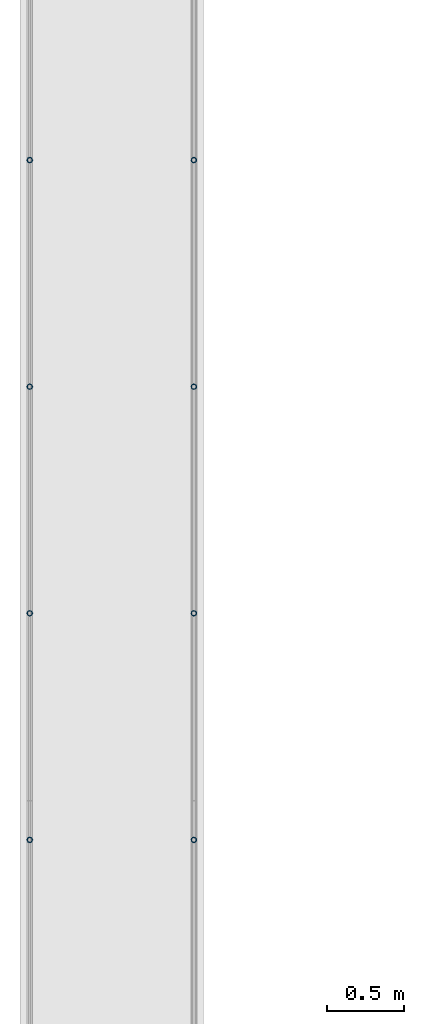
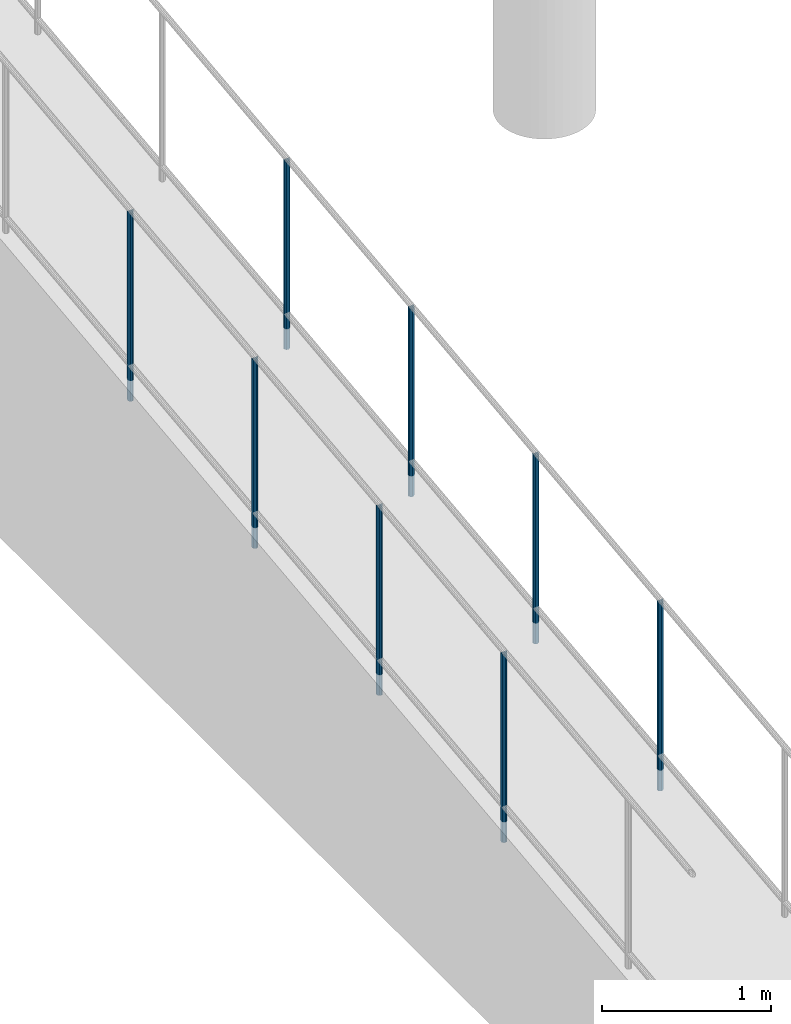
# One storey, part 881 of 1763: 8 columns, 4 elements without a shape of their own.
"""IFC2X3 building model written with IfcOpenShell, lengths in millimetres."""

import ifcopenshell
import ifcopenshell.guid

model = None  # the IFC model being written
_history = None  # IfcOwnerHistory: only IFC2X3 demands one
_inside = {}  # id of a spatial element -> (the spatial element, [elements in it])
_under = {}  # id of a project, library or spatial element -> (it, [spatial elements below it])
_declared = {}  # id of a project -> (the project, [libraries it declares])
_typed = {}  # id of a type object -> (the type object, [elements of that type])
_made_of = {}  # id of a material, layer set ... -> (it, [elements and type objects made of it])


def new_model(schema):
    """Start an empty IFC model of exactly this schema.

    Asked for "IFC4X3", IfcOpenShell would pick the latest addendum, in which some entities
    have other attributes; the version numbers below select the first issue.
    IFC2X3 requires an IfcOwnerHistory on every rooted entity: one is made here for all.
    """
    global model, _history
    if schema == "IFC4X3":
        model = ifcopenshell.file(schema_version=(4, 3, 0, 0))
    else:
        model = ifcopenshell.file(schema=schema)
    _inside.clear()
    _under.clear()
    _declared.clear()
    _typed.clear()
    _made_of.clear()
    _history = None
    if model.schema == "IFC2X3":
        org = make("IfcOrganization", Name="unknown")
        user = make(
            "IfcPersonAndOrganization",
            ThePerson=make("IfcPerson", FamilyName="unknown"),
            TheOrganization=org,
        )
        app = make(
            "IfcApplication",
            ApplicationDeveloper=org,
            Version="unknown",
            ApplicationFullName="unknown",
            ApplicationIdentifier="unknown",
        )
        _history = make(
            "IfcOwnerHistory",
            OwningUser=user,
            OwningApplication=app,
            ChangeAction="ADDED",
            CreationDate=0,
        )
    return model


def make(cls, **values):
    """One entity of the class cls with the attributes given. An attribute that is None is left unset."""
    return model.create_entity(
        cls, **{name: value for name, value in values.items() if value is not None}
    )


def rooted(cls, **values):
    """An entity with a GlobalId (a new one), such as an element, a storey or a relation."""
    return make(cls, GlobalId=ifcopenshell.guid.new(), OwnerHistory=_history, **values)


def si_unit(unit_type, name, prefix=None):
    """IfcSIUnit, for example si_unit("LENGTHUNIT", "METRE", prefix="MILLI")."""
    return make("IfcSIUnit", UnitType=unit_type, Prefix=prefix, Name=name)


def assignment(units):
    """IfcUnitAssignment: the units of a project."""
    return None if units is None else make("IfcUnitAssignment", Units=units)


def point(xyz):
    """IfcCartesianPoint."""
    return None if xyz is None else make("IfcCartesianPoint", Coordinates=xyz)


def direction(xyz):
    """IfcDirection."""
    return None if xyz is None else make("IfcDirection", DirectionRatios=xyz)


def frame(location, z_axis=None, x_axis=None):
    """IfcAxis2Placement3D, a coordinate frame: its origin and axes. An axis left out is left unset."""
    return make(
        "IfcAxis2Placement3D",
        Location=point(location),
        Axis=direction(z_axis),
        RefDirection=direction(x_axis),
    )


def origin_with_axes():
    """The frame at (0, 0, 0) with the z axis (0, 0, 1) and the x axis (1, 0, 0) written out."""
    return frame((0.0, 0.0, 0.0), z_axis=(0.0, 0.0, 1.0), x_axis=(1.0, 0.0, 0.0))


def place(relative_to, where):
    """IfcLocalPlacement: puts the frame where relative to a parent placement (None: the world)."""
    return make(
        "IfcLocalPlacement", PlacementRelTo=relative_to, RelativePlacement=where
    )


def context(
    kind, dimensions, precision=None, world=None, true_north=None, identifier=None
):
    """IfcGeometricRepresentationContext, for example the 3D "Model" context."""
    return make(
        "IfcGeometricRepresentationContext",
        ContextIdentifier=identifier,
        ContextType=kind,
        CoordinateSpaceDimension=dimensions,
        Precision=precision,
        WorldCoordinateSystem=world,
        TrueNorth=true_north,
    )


def subcontext(parent, identifier, kind, view, scale=None):
    """IfcGeometricRepresentationSubContext, for example "Body" below "Model"."""
    return make(
        "IfcGeometricRepresentationSubContext",
        ContextIdentifier=identifier,
        ContextType=kind,
        ParentContext=parent,
        TargetScale=scale,
        TargetView=view,
    )


def project(units=None, contexts=None):
    """IfcProject with its units and contexts."""
    return rooted(
        "IfcProject",
        Name="project",
        RepresentationContexts=contexts,
        UnitsInContext=assignment(units),
    )


def spatial(cls, under=None, at=None, **own):
    """A site, building, storey or space (cls), placed at a placement, below another one or the project."""
    s = rooted(cls, ObjectPlacement=at, **own)
    if under is not None:
        _under.setdefault(under.id(), (under, []))[1].append(s)
    return s


def faces_of(points, faces, orient=None, outer=None):
    """IfcFace entities. A face is a list of loops; a loop is a list of indices into points, from 0.

    orient and outer hold one flag for each loop. By default every Orientation is true, the
    first loop of a face is its IfcFaceOuterBound and the others are IfcFaceBound.
    """
    made = []
    for i, loops in enumerate(faces):
        bounds = []
        for j, loop in enumerate(loops):
            is_outer = j == 0 if outer is None else outer[i][j]
            bounds.append(
                make(
                    "IfcFaceOuterBound" if is_outer else "IfcFaceBound",
                    Bound=make("IfcPolyLoop", Polygon=[points[k] for k in loop]),
                    Orientation=True if orient is None else orient[i][j],
                )
            )
        made.append(make("IfcFace", Bounds=bounds))
    return made


def faceted_brep(points, faces, orient=None, outer=None, voids=None):
    """IfcFacetedBrep: a solid bounded by flat faces; with voids (closed shells), ...WithVoids."""
    shared = [point(p) for p in points]
    hull = make("IfcClosedShell", CfsFaces=faces_of(shared, faces, orient, outer))
    if voids is None:
        return make("IfcFacetedBrep", Outer=hull)
    return make(
        "IfcFacetedBrepWithVoids",
        Outer=hull,
        Voids=[
            make(cls, CfsFaces=faces_of(shared, fs, o, b)) for cls, fs, o, b in voids
        ],
    )


def shape(context_of_items, identifier, shape_type, items):
    """IfcShapeRepresentation: the items that make up one representation, for example the "Body"."""
    return make(
        "IfcShapeRepresentation",
        ContextOfItems=context_of_items,
        RepresentationIdentifier=identifier,
        RepresentationType=shape_type,
        Items=items,
    )


def material(Name=None, Category=None):
    """IfcMaterial."""
    return make("IfcMaterial", Name=Name, Category=Category)


def made_of(thing, what):
    """Note that an element or type object is made of a material, layer set ...; save() writes the relation."""
    if what is not None:
        _made_of.setdefault(what.id(), (what, []))[1].append(thing)
    return thing


def type_object(cls, material=None, **own):
    """A type object (cls), such as IfcWallType, which elements share."""
    return made_of(rooted(cls, **own), material)


def element(
    cls,
    number,
    at=None,
    inside=None,
    cuts=None,
    type_object=None,
    material=None,
    context=None,
    identifier="Body",
    shape_type=None,
    held_by="IfcProductDefinitionShape",
    body=None,
    shapes=None,
    **own,
):
    """One element of the class cls, such as IfcWall. Its Tag is "e" and its number.

    at: its placement. inside: the storey or other place that contains it. cuts: it is an
    opening in that element (IfcRelVoidsElement). A single representation is given by context,
    identifier, shape_type and body (its items); several are given by shapes. held_by: the class
    of the entity that holds the representations. save() writes the other relations.
    """
    e = rooted(cls, Tag="e%d" % number, ObjectPlacement=at, **own)
    if body is not None:
        shapes = [shape(context, identifier, shape_type, body)]
    if shapes is not None:
        e.Representation = make(held_by, Representations=shapes)
    if inside is not None:
        _inside.setdefault(inside.id(), (inside, []))[1].append(e)
    if cuts is not None:
        rooted(
            "IfcRelVoidsElement", RelatingBuildingElement=cuts, RelatedOpeningElement=e
        )
    if type_object is not None:
        _typed.setdefault(type_object.id(), (type_object, []))[1].append(e)
    return made_of(e, material)


def aggregate(whole, parts):
    """IfcRelAggregates: a whole, such as a stair, and the parts it consists of."""
    return rooted("IfcRelAggregates", RelatingObject=whole, RelatedObjects=parts)


def save(model, path):
    """Write the relations noted so far, then the file.

    IfcRelAggregates (storeys below a building ...), IfcRelContainedInSpatialStructure (elements
    in a storey), IfcRelDefinesByType, IfcRelAssociatesMaterial and IfcRelDeclares: one each for
    every whole, place, type object, material and project.
    """
    for whole, parts in _under.values():
        aggregate(whole, parts)
    for where, things in _inside.values():
        rooted(
            "IfcRelContainedInSpatialStructure",
            RelatedElements=things,
            RelatingStructure=where,
        )
    for kind, things in _typed.values():
        rooted("IfcRelDefinesByType", RelatedObjects=things, RelatingType=kind)
    for what, things in _made_of.values():
        rooted("IfcRelAssociatesMaterial", RelatedObjects=things, RelatingMaterial=what)
    for by, libraries in _declared.values():
        rooted("IfcRelDeclares", RelatingContext=by, RelatedDefinitions=libraries)
    model.write(path)


model = new_model("IFC2X3")

# Units and contexts
model_context = context("Model", 3, precision=1e-05, world=origin_with_axes())
body_context = subcontext(model_context, "Body", "Model", "MODEL_VIEW")
ifc_project = project(units=[si_unit("LENGTHUNIT", "METRE", prefix="MILLI"), si_unit("AREAUNIT", "SQUARE_METRE"), si_unit("VOLUMEUNIT", "CUBIC_METRE"), si_unit("MASSUNIT", "GRAM", prefix="KILO"), si_unit("TIMEUNIT", "SECOND"), si_unit("PLANEANGLEUNIT", "RADIAN"), si_unit("SOLIDANGLEUNIT", "STERADIAN"), si_unit("THERMODYNAMICTEMPERATUREUNIT", "DEGREE_CELSIUS"), si_unit("LUMINOUSINTENSITYUNIT", "LUMEN")], contexts=[model_context])

# Site, building, storey
site_placement = place(None, origin_with_axes())
site = spatial("IfcSite", under=ifc_project, at=site_placement, CompositionType="ELEMENT")
building_placement = place(site_placement, origin_with_axes())
building = spatial("IfcBuilding", under=site, at=building_placement, Name="Undefined", CompositionType="ELEMENT")
storey_placement = place(building_placement, origin_with_axes())
storey = spatial("IfcBuildingStorey", under=building, at=storey_placement, Name="Undefined", CompositionType="ELEMENT", Elevation=0.0)

# Assembly, columns
assembly_1_placement = place(storey_placement, origin_with_axes())
assembly_1 = element("IfcElementAssembly", 1, at=assembly_1_placement, inside=storey, Name="GUARDRAIL", AssemblyPlace="NOTDEFINED", PredefinedType="RIGID_FRAME")
ifc_material = material(Name="STEEL/A513")
column_type = type_object("IfcColumnType", PredefinedType="NOTDEFINED")
column_1_placement = place(assembly_1_placement, frame((-97200.6527017878, 1949.23806233376, 5252.99412823663), z_axis=(0.0, -0.999999999989044, 4.68099999989136e-06), x_axis=(0.0, 4.68100000009712e-06, 0.999999999989044)))
column_1 = element("IfcColumn", 2, at=column_1_placement, type_object=column_type, material=ifc_material, Name="POST TUBE", context=body_context, shape_type="Brep", body=[
    faceted_brep([(1371.60068125507, 19.0500000000029, 6.43467501504347e-11), (1360.91947867937, 16.4977839420899, 9.52500000006421), (1363.10672897463, 16.4977839420899, -9.52499999993643), (1352.9316033798, -7.14375000000291, 12.373337956634), (1350.78508867621, 0.0, 14.287500000064), (1350.23827610239, 0.0, 19.0500000000638), (1353.10029570709, -9.52499999999418, 16.4977839421576), (1353.84725557403, -9.52499999997963, 9.99208795664867), (1353.84725557403, 9.52500000000873, 9.99208795661957), (1353.10029570709, 9.52499999999418, 16.4977839421576), (1352.93160337979, 7.14375000000291, 12.373337956634), (1357.04134215904, 12.3733379565674, 7.14375000006385), (1359.78829874193, 14.2875000000058, 6.3664629124105e-11), (1358.68177988048, 12.3733379565674, -7.14374999993652), (1356.14176448041, 9.52500000000873, -9.99208795649247), (1356.88872434735, 9.52499999999418, -16.4977839420305), (1355.77292485998, 7.14375000000291, -12.3733379565072), (1354.0659641191, 0.0, -14.2874999999372), (1354.61277669292, 0.0, -19.049999999937), (1355.77292485999, -7.14375000000291, -12.3733379565072), (1356.14176448041, -9.52499999997963, -9.99208795652157), (1356.88872434735, -9.52499999999418, -16.4977839420305), (1371.60068125632, -19.0499999999884, 2.08501660381444e-10), (1363.10672897463, -16.4977839420899, -9.52499999993643), (1360.91947867937, -16.4977839420899, 9.52500000006421), (1358.68177988052, -12.3733379565674, -7.14374999993652), (1359.78829874197, -14.2875000000058, 6.3664629124105e-11), (1357.04134215908, -12.3733379565674, 7.14375000006407), (0.0, -16.4977839420899, -9.52500000000146), (0.0, -9.52499999999418, -16.4977839420935), (1.45519152283669e-11, 1.81898940354586e-12, -19.0499999999993), (0.0, 9.52499999999418, -16.4977839420935), (0.0, 16.4977839420899, -9.52500000000146), (0.0, 19.0500000000029, 0.0), (0.0, 16.4977839420899, 9.52500000000146), (0.0, 9.52499999999418, 16.4977839420935), (1.45519152283669e-11, 1.81898940354586e-12, 19.0499999999993), (0.0, -9.52499999999418, 16.4977839420935), (0.0, -16.4977839420899, 9.52500000000146), (0.0, -19.0500000000029, 0.0), (0.0, -12.3733379565674, -7.14374999999927), (0.0, -7.14375000000291, -12.373337956571), (0.0, 0.0, -14.2874999999985), (0.0, 7.14375000000291, -12.373337956571), (0.0, 12.3733379565674, -7.14374999999927), (0.0, 14.2875000000058, 0.0), (0.0, 12.3733379565674, 7.14374999999927), (0.0, 7.14375000000291, 12.373337956571), (0.0, 0.0, 14.2874999999985), (0.0, -7.14375000000291, 12.373337956571), (0.0, -12.3733379565674, 7.14374999999927), (0.0, -14.2875000000058, 0.0)], [[[0, 1, 2]], [[3, 4, 5, 6, 7]], [[8, 9, 5, 4, 10]], [[2, 1, 9, 8, 11, 12, 13, 14, 15]], [[15, 14, 16, 17, 18]], [[18, 17, 19, 20, 21]], [[22, 23, 24]], [[21, 20, 25, 26, 27, 7, 6, 24, 23]], [[28, 29, 21, 23]], [[29, 30, 18, 21]], [[30, 31, 15, 18]], [[31, 32, 2, 15]], [[32, 33, 0, 2]], [[33, 34, 1, 0]], [[34, 35, 9, 1]], [[35, 36, 5, 9]], [[36, 37, 6, 5]], [[37, 38, 24, 6]], [[38, 39, 22, 24]], [[39, 28, 23, 22]], [[38, 37, 36, 35, 34, 33, 32, 31, 30, 29, 28, 39], [40, 41, 42, 43, 44, 45, 46, 47, 48, 49, 50, 51]], [[40, 51, 26, 25]], [[19, 41, 40, 25, 20]], [[42, 41, 19, 17]], [[43, 42, 17, 16]], [[44, 43, 16, 14, 13]], [[45, 44, 13, 12]], [[46, 45, 12, 11]], [[10, 47, 46, 11, 8]], [[48, 47, 10, 4]], [[49, 48, 4, 3]], [[50, 49, 3, 7, 27]], [[51, 50, 27, 26]]]),
])
column_2_placement = place(assembly_1_placement, frame((-97200.6527017878, 476.037327690622, 5083.85314479949), z_axis=(0.0, -0.999999999989044, 4.68099999989136e-06), x_axis=(0.0, 4.68100000009712e-06, 0.999999999989044)))
column_2 = element("IfcColumn", 3, at=column_2_placement, type_object=column_type, material=ifc_material, Name="POST TUBE", context=body_context, shape_type="Brep", body=[
    faceted_brep([(1371.60074802696, 19.0500000000029, -4.95674612466246e-10), (1360.91954353543, 16.4977839420899, 9.52499999992688), (1363.1068023618, 16.4977839420899, -9.52500000007285), (1352.93166657158, -7.14375000000291, 12.3733379564974), (1350.78515091293, 0.0, 14.2874999999276), (1350.23833620634, 0.0, 19.0499999999279), (1353.10035708436, -9.52499999999418, 16.4977839420208), (1353.84731986472, -9.52499999997963, 9.99208795651202), (1353.84731986473, 9.52500000000873, 9.99208795648292), (1353.10035708436, 9.52499999999418, 16.4977839420208), (1352.93166657157, 7.14375000000291, 12.3733379564974), (1357.04140787087, 12.3733379565674, 7.14374999992697), (1359.7883677507, 14.2875000000058, -7.27595761418343e-11), (1358.68185199063, 12.3733379565674, -7.14375000007294), (1356.14183772056, 9.52500000000873, -9.99208795662844), (1356.88880050093, 9.52499999999418, -16.4977839421663), (1355.77299913398, 7.14375000000291, -12.3733379566434), (1354.06603915248, 0.0, -14.2875000000727), (1354.61285385908, 0.0, -19.0500000000725), (1355.77299913399, -7.14375000000291, -12.3733379566434), (1356.14183772056, -9.52499999997963, -9.992087956658), (1356.88880050093, -9.52499999999418, -16.4977839421663), (1371.60075086449, -19.0499999999884, 1.21417542686686e-10), (1363.1068023618, -16.4977839420899, -9.52500000007285), (1360.91954353543, -16.4977839420899, 9.52499999992688), (1358.68185199066, -12.3733379565674, -7.14375000007294), (1359.78836775073, -14.2875000000058, -7.27595761418343e-11), (1357.0414078709, -12.3733379565674, 7.14374999992697), (0.0, -16.4977839420899, -9.52500000000146), (0.0, -9.52499999999418, -16.4977839420935), (1.45519152283669e-11, 1.81898940354586e-12, -19.0499999999993), (0.0, 9.52499999999418, -16.4977839420935), (0.0, 16.4977839420899, -9.52500000000146), (0.0, 19.0500000000029, 0.0), (0.0, 16.4977839420899, 9.52500000000146), (0.0, 9.52499999999418, 16.4977839420935), (1.45519152283669e-11, 1.81898940354586e-12, 19.0499999999993), (0.0, -9.52499999999418, 16.4977839420935), (0.0, -16.4977839420899, 9.52500000000146), (0.0, -19.0500000000029, 0.0), (0.0, -12.3733379565674, -7.14374999999927), (0.0, -7.14375000000291, -12.373337956571), (0.0, 0.0, -14.2874999999985), (0.0, 7.14375000000291, -12.373337956571), (0.0, 12.3733379565674, -7.14374999999927), (0.0, 14.2875000000058, 0.0), (0.0, 12.3733379565674, 7.14374999999927), (0.0, 7.14375000000291, 12.373337956571), (0.0, 0.0, 14.2874999999985), (0.0, -7.14375000000291, 12.373337956571), (0.0, -12.3733379565674, 7.14374999999927), (0.0, -14.2875000000058, 0.0)], [[[0, 1, 2]], [[3, 4, 5, 6, 7]], [[8, 9, 5, 4, 10]], [[2, 1, 9, 8, 11, 12, 13, 14, 15]], [[15, 14, 16, 17, 18]], [[18, 17, 19, 20, 21]], [[22, 23, 24]], [[21, 20, 25, 26, 27, 7, 6, 24, 23]], [[28, 29, 21, 23]], [[29, 30, 18, 21]], [[30, 31, 15, 18]], [[31, 32, 2, 15]], [[32, 33, 0, 2]], [[33, 34, 1, 0]], [[34, 35, 9, 1]], [[35, 36, 5, 9]], [[36, 37, 6, 5]], [[37, 38, 24, 6]], [[38, 39, 22, 24]], [[39, 28, 23, 22]], [[38, 37, 36, 35, 34, 33, 32, 31, 30, 29, 28, 39], [40, 41, 42, 43, 44, 45, 46, 47, 48, 49, 50, 51]], [[40, 51, 26, 25]], [[19, 41, 40, 25, 20]], [[42, 41, 19, 17]], [[43, 42, 17, 16]], [[44, 43, 16, 14, 13]], [[45, 44, 13, 12]], [[46, 45, 12, 11]], [[10, 47, 46, 11, 8]], [[48, 47, 10, 4]], [[49, 48, 4, 3]], [[50, 49, 3, 7, 27]], [[51, 50, 27, 26]]]),
])
column_3_placement = place(assembly_1_placement, frame((-97200.6527017878, -997.16267378922, 4914.71224553822), z_axis=(0.0, -0.999999999989044, 4.68099999989136e-06), x_axis=(0.0, 4.68100000009712e-06, 0.999999999989044)))
column_3 = element("IfcColumn", 4, at=column_3_placement, type_object=column_type, material=ifc_material, Name="POST TUBE", context=body_context, shape_type="Brep", body=[
    faceted_brep([(1371.60074802696, 19.0500000000029, -4.95674612466246e-10), (1360.88226427304, 16.4977839420899, 9.52500000002783), (1363.06893704611, 16.4977839420899, -9.5249999999719), (1352.89450163934, -7.14375000000291, 12.3733379565979), (1350.74805158422, 0.0, 14.2875000000276), (1350.20138339095, 0.0, 19.0500000000276), (1353.06331679776, -9.52499999999418, 16.4977839421211), (1353.8100794372, -9.52499999997963, 9.99208795661241), (1353.8100794372, 9.52500000000873, 9.9920879565833), (1353.06331679776, 9.52499999999418, 16.4977839421211), (1352.89450163932, 7.14375000000291, 12.3733379565979), (1357.00406982313, 12.3733379565674, 7.14375000002781), (1359.75080321677, 14.2875000000058, 2.79669620795175e-11), (1358.64407440294, 12.3733379565674, -7.1437499999721), (1356.1039825008, 9.52500000000873, -9.99208795652771), (1356.85074514025, 9.52499999999418, -16.4977839420656), (1355.7350728962, 7.14375000000291, -12.3733379565422), (1354.02806074383, 0.0, -14.2874999999721), (1354.5747289371, 0.0, -19.049999999972), (1355.73507289621, -7.14375000000291, -12.3733379565422), (1356.10398250081, -9.52499999997963, -9.99208795655682), (1356.85074514025, -9.52499999999418, -16.4977839420656), (1371.56363438805, -19.0499999999884, -0.00426213161995292), (1363.06893704611, -16.4977839420899, -9.5249999999719), (1360.88226427304, -16.4977839420899, 9.52500000002783), (1358.64407440297, -12.3733379565674, -7.1437499999721), (1359.7508032168, -14.2875000000058, 2.79669620795175e-11), (1357.00406982317, -12.3733379565674, 7.14375000002781), (0.0, -16.4977839420899, -9.52500000000146), (0.0, -9.52499999999418, -16.4977839420935), (1.45519152283669e-11, 1.81898940354586e-12, -19.0499999999993), (0.0, 9.52499999999418, -16.4977839420935), (0.0, 16.4977839420899, -9.52500000000146), (0.0, 19.0500000000029, 0.0), (0.0, 16.4977839420899, 9.52500000000146), (0.0, 9.52499999999418, 16.4977839420935), (1.45519152283669e-11, 1.81898940354586e-12, 19.0499999999993), (0.0, -9.52499999999418, 16.4977839420935), (0.0, -16.4977839420899, 9.52500000000146), (0.0, -19.0500000000029, 0.0), (0.0, -12.3733379565674, -7.14374999999927), (0.0, -7.14375000000291, -12.373337956571), (0.0, 0.0, -14.2874999999985), (0.0, 7.14375000000291, -12.373337956571), (0.0, 12.3733379565674, -7.14374999999927), (0.0, 14.2875000000058, 0.0), (0.0, 12.3733379565674, 7.14374999999927), (0.0, 7.14375000000291, 12.373337956571), (0.0, 0.0, 14.2874999999985), (0.0, -7.14375000000291, 12.373337956571), (0.0, -12.3733379565674, 7.14374999999927), (0.0, -14.2875000000058, 0.0)], [[[0, 1, 2]], [[3, 4, 5, 6, 7]], [[8, 9, 5, 4, 10]], [[2, 1, 9, 8, 11, 12, 13, 14, 15]], [[15, 14, 16, 17, 18]], [[18, 17, 19, 20, 21]], [[22, 23, 24]], [[21, 20, 25, 26, 27, 7, 6, 24, 23]], [[28, 29, 21, 23]], [[29, 30, 18, 21]], [[30, 31, 15, 18]], [[31, 32, 2, 15]], [[32, 33, 0, 2]], [[33, 34, 1, 0]], [[34, 35, 9, 1]], [[35, 36, 5, 9]], [[36, 37, 6, 5]], [[37, 38, 24, 6]], [[38, 39, 22, 24]], [[39, 28, 23, 22]], [[38, 37, 36, 35, 34, 33, 32, 31, 30, 29, 28, 39], [40, 41, 42, 43, 44, 45, 46, 47, 48, 49, 50, 51]], [[40, 51, 26, 25]], [[19, 41, 40, 25, 20]], [[42, 41, 19, 17]], [[43, 42, 17, 16]], [[44, 43, 16, 14, 13]], [[45, 44, 13, 12]], [[46, 45, 12, 11]], [[10, 47, 46, 11, 8]], [[48, 47, 10, 4]], [[49, 48, 4, 3]], [[50, 49, 3, 7, 27]], [[51, 50, 27, 26]]]),
])
aggregate(assembly_1, [column_1, column_2, column_3])

# Assembly, column
assembly_2_placement = place(storey_placement, origin_with_axes())
assembly_2 = element("IfcElementAssembly", 5, at=assembly_2_placement, inside=storey, Name="GUARDRAIL", AssemblyPlace="NOTDEFINED", PredefinedType="RIGID_FRAME")
column_4_placement = place(assembly_2_placement, frame((-97200.6527017878, -2470.36267526906, 4745.57134627696), z_axis=(0.0, -0.999999999989044, 4.68099999989136e-06), x_axis=(0.0, 4.68100000009712e-06, 0.999999999989044)))
column_4 = element("IfcColumn", 6, at=column_4_placement, type_object=column_type, material=ifc_material, Name="POST TUBE", context=body_context, shape_type="Brep", body=[
    faceted_brep([(1371.60074802696, 19.0500000000029, -4.95674612466246e-10), (1360.91954353543, 16.4977839420899, 9.52499999992688), (1363.1068023618, 16.4977839420899, -9.52500000007285), (1352.93166657158, -7.14375000000291, 12.3733379564974), (1350.78515091293, 0.0, 14.2874999999276), (1350.23833620634, 0.0, 19.0499999999279), (1353.10035708436, -9.52499999999418, 16.4977839420208), (1353.84731986472, -9.52499999997963, 9.99208795651202), (1353.84731986473, 9.52500000000873, 9.99208795648292), (1353.10035708436, 9.52499999999418, 16.4977839420208), (1352.93166657157, 7.14375000000291, 12.3733379564974), (1357.04140787087, 12.3733379565674, 7.14374999992697), (1359.7883677507, 14.2875000000058, -7.27595761418343e-11), (1358.68185199063, 12.3733379565674, -7.14375000007294), (1356.14183772056, 9.52500000000873, -9.99208795662844), (1356.88880050093, 9.52499999999418, -16.4977839421663), (1355.77299913398, 7.14375000000291, -12.3733379566434), (1354.06603915248, 0.0, -14.2875000000727), (1354.61285385908, 0.0, -19.0500000000725), (1355.77299913399, -7.14375000000291, -12.3733379566434), (1356.14183772056, -9.52499999997963, -9.992087956658), (1356.88880050093, -9.52499999999418, -16.4977839421663), (1371.60075086449, -19.0499999999884, 1.21417542686686e-10), (1363.1068023618, -16.4977839420899, -9.52500000007285), (1360.91954353543, -16.4977839420899, 9.52499999992688), (1358.68185199066, -12.3733379565674, -7.14375000007294), (1359.78836775073, -14.2875000000058, -7.27595761418343e-11), (1357.0414078709, -12.3733379565674, 7.14374999992697), (0.0, -16.4977839420899, -9.52500000000146), (0.0, -9.52499999999418, -16.4977839420935), (1.45519152283669e-11, 1.81898940354586e-12, -19.0499999999993), (0.0, 9.52499999999418, -16.4977839420935), (0.0, 16.4977839420899, -9.52500000000146), (0.0, 19.0500000000029, 0.0), (0.0, 16.4977839420899, 9.52500000000146), (0.0, 9.52499999999418, 16.4977839420935), (1.45519152283669e-11, 1.81898940354586e-12, 19.0499999999993), (0.0, -9.52499999999418, 16.4977839420935), (0.0, -16.4977839420899, 9.52500000000146), (0.0, -19.0500000000029, 0.0), (0.0, -12.3733379565674, -7.14374999999927), (0.0, -7.14375000000291, -12.373337956571), (0.0, 0.0, -14.2874999999985), (0.0, 7.14375000000291, -12.373337956571), (0.0, 12.3733379565674, -7.14374999999927), (0.0, 14.2875000000058, 0.0), (0.0, 12.3733379565674, 7.14374999999927), (0.0, 7.14375000000291, 12.373337956571), (0.0, 0.0, 14.2874999999985), (0.0, -7.14375000000291, 12.373337956571), (0.0, -12.3733379565674, 7.14374999999927), (0.0, -14.2875000000058, 0.0)], [[[0, 1, 2]], [[3, 4, 5, 6, 7]], [[8, 9, 5, 4, 10]], [[2, 1, 9, 8, 11, 12, 13, 14, 15]], [[15, 14, 16, 17, 18]], [[18, 17, 19, 20, 21]], [[22, 23, 24]], [[21, 20, 25, 26, 27, 7, 6, 24, 23]], [[28, 29, 21, 23]], [[29, 30, 18, 21]], [[30, 31, 15, 18]], [[31, 32, 2, 15]], [[32, 33, 0, 2]], [[33, 34, 1, 0]], [[34, 35, 9, 1]], [[35, 36, 5, 9]], [[36, 37, 6, 5]], [[37, 38, 24, 6]], [[38, 39, 22, 24]], [[39, 28, 23, 22]], [[38, 37, 36, 35, 34, 33, 32, 31, 30, 29, 28, 39], [40, 41, 42, 43, 44, 45, 46, 47, 48, 49, 50, 51]], [[40, 51, 26, 25]], [[19, 41, 40, 25, 20]], [[42, 41, 19, 17]], [[43, 42, 17, 16]], [[44, 43, 16, 14, 13]], [[45, 44, 13, 12]], [[46, 45, 12, 11]], [[10, 47, 46, 11, 8]], [[48, 47, 10, 4]], [[49, 48, 4, 3]], [[50, 49, 3, 7, 27]], [[51, 50, 27, 26]]]),
])
aggregate(assembly_2, [column_4])

# Assembly, columns
assembly_3_placement = place(storey_placement, origin_with_axes())
assembly_3 = element("IfcElementAssembly", 7, at=assembly_3_placement, inside=storey, Name="GUARDRAIL", AssemblyPlace="NOTDEFINED", PredefinedType="RIGID_FRAME")
column_5_placement = place(assembly_3_placement, frame((-96133.8527017878, 1949.23806233376, 5252.99412823663), z_axis=(0.0, -0.999999999989044, 4.68099999989136e-06), x_axis=(0.0, 4.68100000009712e-06, 0.999999999989044)))
column_5 = element("IfcColumn", 8, at=column_5_placement, type_object=column_type, material=ifc_material, Name="POST TUBE", context=body_context, shape_type="Brep", body=[
    faceted_brep([(1371.60068125507, 19.0500000000029, 6.43467501504347e-11), (1360.91947867937, 16.4977839420899, 9.52500000006421), (1363.10672897463, 16.4977839420899, -9.52499999993643), (1352.9316033798, -7.14375000000291, 12.373337956634), (1350.78508867621, 0.0, 14.287500000064), (1350.23827610239, 0.0, 19.0500000000638), (1353.10029570709, -9.52499999999418, 16.4977839421576), (1353.84725557403, -9.52499999997963, 9.99208795664867), (1353.84725557403, 9.52500000000873, 9.99208795661957), (1353.10029570709, 9.52499999999418, 16.4977839421576), (1352.93160337979, 7.14375000000291, 12.373337956634), (1357.04134215904, 12.3733379565674, 7.14375000006385), (1359.78829874193, 14.2875000000058, 6.3664629124105e-11), (1358.68177988048, 12.3733379565674, -7.14374999993652), (1356.14176448041, 9.52500000000873, -9.99208795649247), (1356.88872434735, 9.52499999999418, -16.4977839420305), (1355.77292485998, 7.14375000000291, -12.3733379565072), (1354.0659641191, 0.0, -14.2874999999372), (1354.61277669292, 0.0, -19.049999999937), (1355.77292485999, -7.14375000000291, -12.3733379565072), (1356.14176448041, -9.52499999997963, -9.99208795652157), (1356.88872434735, -9.52499999999418, -16.4977839420305), (1371.60068125632, -19.0499999999884, 2.08501660381444e-10), (1363.10672897463, -16.4977839420899, -9.52499999993643), (1360.91947867937, -16.4977839420899, 9.52500000006421), (1358.68177988052, -12.3733379565674, -7.14374999993652), (1359.78829874197, -14.2875000000058, 6.3664629124105e-11), (1357.04134215908, -12.3733379565674, 7.14375000006407), (0.0, -16.4977839420899, -9.52500000000146), (0.0, -9.52499999999418, -16.4977839420935), (1.45519152283669e-11, 1.81898940354586e-12, -19.0499999999993), (0.0, 9.52499999999418, -16.4977839420935), (0.0, 16.4977839420899, -9.52500000000146), (0.0, 19.0500000000029, 0.0), (0.0, 16.4977839420899, 9.52500000000146), (0.0, 9.52499999999418, 16.4977839420935), (1.45519152283669e-11, 1.81898940354586e-12, 19.0499999999993), (0.0, -9.52499999999418, 16.4977839420935), (0.0, -16.4977839420899, 9.52500000000146), (0.0, -19.0500000000029, 0.0), (0.0, -12.3733379565674, -7.14374999999927), (0.0, -7.14375000000291, -12.373337956571), (0.0, 0.0, -14.2874999999985), (0.0, 7.14375000000291, -12.373337956571), (0.0, 12.3733379565674, -7.14374999999927), (0.0, 14.2875000000058, 0.0), (0.0, 12.3733379565674, 7.14374999999927), (0.0, 7.14375000000291, 12.373337956571), (0.0, 0.0, 14.2874999999985), (0.0, -7.14375000000291, 12.373337956571), (0.0, -12.3733379565674, 7.14374999999927), (0.0, -14.2875000000058, 0.0)], [[[0, 1, 2]], [[3, 4, 5, 6, 7]], [[8, 9, 5, 4, 10]], [[2, 1, 9, 8, 11, 12, 13, 14, 15]], [[15, 14, 16, 17, 18]], [[18, 17, 19, 20, 21]], [[22, 23, 24]], [[21, 20, 25, 26, 27, 7, 6, 24, 23]], [[28, 29, 21, 23]], [[29, 30, 18, 21]], [[30, 31, 15, 18]], [[31, 32, 2, 15]], [[32, 33, 0, 2]], [[33, 34, 1, 0]], [[34, 35, 9, 1]], [[35, 36, 5, 9]], [[36, 37, 6, 5]], [[37, 38, 24, 6]], [[38, 39, 22, 24]], [[39, 28, 23, 22]], [[38, 37, 36, 35, 34, 33, 32, 31, 30, 29, 28, 39], [40, 41, 42, 43, 44, 45, 46, 47, 48, 49, 50, 51]], [[40, 51, 26, 25]], [[19, 41, 40, 25, 20]], [[42, 41, 19, 17]], [[43, 42, 17, 16]], [[44, 43, 16, 14, 13]], [[45, 44, 13, 12]], [[46, 45, 12, 11]], [[10, 47, 46, 11, 8]], [[48, 47, 10, 4]], [[49, 48, 4, 3]], [[50, 49, 3, 7, 27]], [[51, 50, 27, 26]]]),
])
column_6_placement = place(assembly_3_placement, frame((-96133.8527017878, 476.037327690622, 5083.85314479949), z_axis=(0.0, -0.999999999989044, 4.68099999989136e-06), x_axis=(0.0, 4.68100000009712e-06, 0.999999999989044)))
column_6 = element("IfcColumn", 9, at=column_6_placement, type_object=column_type, material=ifc_material, Name="POST TUBE", context=body_context, shape_type="Brep", body=[
    faceted_brep([(1371.60074802696, 19.0500000000029, -4.95674612466246e-10), (1360.91954353543, 16.4977839420899, 9.52499999992688), (1363.1068023618, 16.4977839420899, -9.52500000007285), (1352.93166657158, -7.14375000000291, 12.3733379564974), (1350.78515091293, 0.0, 14.2874999999276), (1350.23833620634, 0.0, 19.0499999999279), (1353.10035708436, -9.52499999999418, 16.4977839420208), (1353.84731986472, -9.52499999997963, 9.99208795651202), (1353.84731986473, 9.52500000000873, 9.99208795648292), (1353.10035708436, 9.52499999999418, 16.4977839420208), (1352.93166657157, 7.14375000000291, 12.3733379564974), (1357.04140787087, 12.3733379565674, 7.14374999992697), (1359.7883677507, 14.2875000000058, -7.27595761418343e-11), (1358.68185199063, 12.3733379565674, -7.14375000007294), (1356.14183772056, 9.52500000000873, -9.99208795662844), (1356.88880050093, 9.52499999999418, -16.4977839421663), (1355.77299913398, 7.14375000000291, -12.3733379566434), (1354.06603915248, 0.0, -14.2875000000727), (1354.61285385908, 0.0, -19.0500000000725), (1355.77299913399, -7.14375000000291, -12.3733379566434), (1356.14183772056, -9.52499999997963, -9.992087956658), (1356.88880050093, -9.52499999999418, -16.4977839421663), (1371.60075086449, -19.0499999999884, 1.21417542686686e-10), (1363.1068023618, -16.4977839420899, -9.52500000007285), (1360.91954353543, -16.4977839420899, 9.52499999992688), (1358.68185199066, -12.3733379565674, -7.14375000007294), (1359.78836775073, -14.2875000000058, -7.27595761418343e-11), (1357.0414078709, -12.3733379565674, 7.14374999992697), (0.0, -16.4977839420899, -9.52500000000146), (0.0, -9.52499999999418, -16.4977839420935), (1.45519152283669e-11, 1.81898940354586e-12, -19.0499999999993), (0.0, 9.52499999999418, -16.4977839420935), (0.0, 16.4977839420899, -9.52500000000146), (0.0, 19.0500000000029, 0.0), (0.0, 16.4977839420899, 9.52500000000146), (0.0, 9.52499999999418, 16.4977839420935), (1.45519152283669e-11, 1.81898940354586e-12, 19.0499999999993), (0.0, -9.52499999999418, 16.4977839420935), (0.0, -16.4977839420899, 9.52500000000146), (0.0, -19.0500000000029, 0.0), (0.0, -12.3733379565674, -7.14374999999927), (0.0, -7.14375000000291, -12.373337956571), (0.0, 0.0, -14.2874999999985), (0.0, 7.14375000000291, -12.373337956571), (0.0, 12.3733379565674, -7.14374999999927), (0.0, 14.2875000000058, 0.0), (0.0, 12.3733379565674, 7.14374999999927), (0.0, 7.14375000000291, 12.373337956571), (0.0, 0.0, 14.2874999999985), (0.0, -7.14375000000291, 12.373337956571), (0.0, -12.3733379565674, 7.14374999999927), (0.0, -14.2875000000058, 0.0)], [[[0, 1, 2]], [[3, 4, 5, 6, 7]], [[8, 9, 5, 4, 10]], [[2, 1, 9, 8, 11, 12, 13, 14, 15]], [[15, 14, 16, 17, 18]], [[18, 17, 19, 20, 21]], [[22, 23, 24]], [[21, 20, 25, 26, 27, 7, 6, 24, 23]], [[28, 29, 21, 23]], [[29, 30, 18, 21]], [[30, 31, 15, 18]], [[31, 32, 2, 15]], [[32, 33, 0, 2]], [[33, 34, 1, 0]], [[34, 35, 9, 1]], [[35, 36, 5, 9]], [[36, 37, 6, 5]], [[37, 38, 24, 6]], [[38, 39, 22, 24]], [[39, 28, 23, 22]], [[38, 37, 36, 35, 34, 33, 32, 31, 30, 29, 28, 39], [40, 41, 42, 43, 44, 45, 46, 47, 48, 49, 50, 51]], [[40, 51, 26, 25]], [[19, 41, 40, 25, 20]], [[42, 41, 19, 17]], [[43, 42, 17, 16]], [[44, 43, 16, 14, 13]], [[45, 44, 13, 12]], [[46, 45, 12, 11]], [[10, 47, 46, 11, 8]], [[48, 47, 10, 4]], [[49, 48, 4, 3]], [[50, 49, 3, 7, 27]], [[51, 50, 27, 26]]]),
])
column_7_placement = place(assembly_3_placement, frame((-96133.8527017878, -997.16267378922, 4914.71224553822), z_axis=(0.0, -0.999999999989044, 4.68099999989136e-06), x_axis=(0.0, 4.68100000009712e-06, 0.999999999989044)))
column_7 = element("IfcColumn", 10, at=column_7_placement, type_object=column_type, material=ifc_material, Name="POST TUBE", context=body_context, shape_type="Brep", body=[
    faceted_brep([(1371.60074802696, 19.0500000000029, -4.95674612466246e-10), (1360.88226427304, 16.4977839420899, 9.52500000002783), (1363.06893704611, 16.4977839420899, -9.5249999999719), (1352.89450163934, -7.14375000000291, 12.3733379565979), (1350.74805158422, 0.0, 14.2875000000276), (1350.20138339095, 0.0, 19.0500000000276), (1353.06331679776, -9.52499999999418, 16.4977839421211), (1353.8100794372, -9.52499999997963, 9.99208795661241), (1353.8100794372, 9.52500000000873, 9.9920879565833), (1353.06331679776, 9.52499999999418, 16.4977839421211), (1352.89450163932, 7.14375000000291, 12.3733379565979), (1357.00406982313, 12.3733379565674, 7.14375000002781), (1359.75080321677, 14.2875000000058, 2.79669620795175e-11), (1358.64407440294, 12.3733379565674, -7.1437499999721), (1356.1039825008, 9.52500000000873, -9.99208795652771), (1356.85074514025, 9.52499999999418, -16.4977839420656), (1355.7350728962, 7.14375000000291, -12.3733379565422), (1354.02806074383, 0.0, -14.2874999999721), (1354.5747289371, 0.0, -19.049999999972), (1355.73507289621, -7.14375000000291, -12.3733379565422), (1356.10398250081, -9.52499999997963, -9.99208795655682), (1356.85074514025, -9.52499999999418, -16.4977839420656), (1371.56363438805, -19.0499999999884, -0.00426213161995292), (1363.06893704611, -16.4977839420899, -9.5249999999719), (1360.88226427304, -16.4977839420899, 9.52500000002783), (1358.64407440297, -12.3733379565674, -7.1437499999721), (1359.7508032168, -14.2875000000058, 2.79669620795175e-11), (1357.00406982317, -12.3733379565674, 7.14375000002781), (0.0, -16.4977839420899, -9.52500000000146), (0.0, -9.52499999999418, -16.4977839420935), (1.45519152283669e-11, 1.81898940354586e-12, -19.0499999999993), (0.0, 9.52499999999418, -16.4977839420935), (0.0, 16.4977839420899, -9.52500000000146), (0.0, 19.0500000000029, 0.0), (0.0, 16.4977839420899, 9.52500000000146), (0.0, 9.52499999999418, 16.4977839420935), (1.45519152283669e-11, 1.81898940354586e-12, 19.0499999999993), (0.0, -9.52499999999418, 16.4977839420935), (0.0, -16.4977839420899, 9.52500000000146), (0.0, -19.0500000000029, 0.0), (0.0, -12.3733379565674, -7.14374999999927), (0.0, -7.14375000000291, -12.373337956571), (0.0, 0.0, -14.2874999999985), (0.0, 7.14375000000291, -12.373337956571), (0.0, 12.3733379565674, -7.14374999999927), (0.0, 14.2875000000058, 0.0), (0.0, 12.3733379565674, 7.14374999999927), (0.0, 7.14375000000291, 12.373337956571), (0.0, 0.0, 14.2874999999985), (0.0, -7.14375000000291, 12.373337956571), (0.0, -12.3733379565674, 7.14374999999927), (0.0, -14.2875000000058, 0.0)], [[[0, 1, 2]], [[3, 4, 5, 6, 7]], [[8, 9, 5, 4, 10]], [[2, 1, 9, 8, 11, 12, 13, 14, 15]], [[15, 14, 16, 17, 18]], [[18, 17, 19, 20, 21]], [[22, 23, 24]], [[21, 20, 25, 26, 27, 7, 6, 24, 23]], [[28, 29, 21, 23]], [[29, 30, 18, 21]], [[30, 31, 15, 18]], [[31, 32, 2, 15]], [[32, 33, 0, 2]], [[33, 34, 1, 0]], [[34, 35, 9, 1]], [[35, 36, 5, 9]], [[36, 37, 6, 5]], [[37, 38, 24, 6]], [[38, 39, 22, 24]], [[39, 28, 23, 22]], [[38, 37, 36, 35, 34, 33, 32, 31, 30, 29, 28, 39], [40, 41, 42, 43, 44, 45, 46, 47, 48, 49, 50, 51]], [[40, 51, 26, 25]], [[19, 41, 40, 25, 20]], [[42, 41, 19, 17]], [[43, 42, 17, 16]], [[44, 43, 16, 14, 13]], [[45, 44, 13, 12]], [[46, 45, 12, 11]], [[10, 47, 46, 11, 8]], [[48, 47, 10, 4]], [[49, 48, 4, 3]], [[50, 49, 3, 7, 27]], [[51, 50, 27, 26]]]),
])
aggregate(assembly_3, [column_5, column_6, column_7])

# Assembly, column
assembly_4_placement = place(storey_placement, origin_with_axes())
assembly_4 = element("IfcElementAssembly", 11, at=assembly_4_placement, inside=storey, Name="GUARDRAIL", AssemblyPlace="NOTDEFINED", PredefinedType="RIGID_FRAME")
column_8_placement = place(assembly_4_placement, frame((-96133.8527017878, -2470.36267526906, 4745.57134627696), z_axis=(0.0, -0.999999999989044, 4.68099999989136e-06), x_axis=(0.0, 4.68100000009712e-06, 0.999999999989044)))
column_8 = element("IfcColumn", 12, at=column_8_placement, type_object=column_type, material=ifc_material, Name="POST TUBE", context=body_context, shape_type="Brep", body=[
    faceted_brep([(1371.60074802696, 19.0500000000029, -4.95674612466246e-10), (1360.91954353543, 16.4977839420899, 9.52499999992688), (1363.1068023618, 16.4977839420899, -9.52500000007285), (1352.93166657158, -7.14375000000291, 12.3733379564974), (1350.78515091293, 0.0, 14.2874999999276), (1350.23833620634, 0.0, 19.0499999999279), (1353.10035708436, -9.52499999999418, 16.4977839420208), (1353.84731986472, -9.52499999997963, 9.99208795651202), (1353.84731986473, 9.52500000000873, 9.99208795648292), (1353.10035708436, 9.52499999999418, 16.4977839420208), (1352.93166657157, 7.14375000000291, 12.3733379564974), (1357.04140787087, 12.3733379565674, 7.14374999992697), (1359.7883677507, 14.2875000000058, -7.27595761418343e-11), (1358.68185199063, 12.3733379565674, -7.14375000007294), (1356.14183772056, 9.52500000000873, -9.99208795662844), (1356.88880050093, 9.52499999999418, -16.4977839421663), (1355.77299913398, 7.14375000000291, -12.3733379566434), (1354.06603915248, 0.0, -14.2875000000727), (1354.61285385908, 0.0, -19.0500000000725), (1355.77299913399, -7.14375000000291, -12.3733379566434), (1356.14183772056, -9.52499999997963, -9.992087956658), (1356.88880050093, -9.52499999999418, -16.4977839421663), (1371.60075086449, -19.0499999999884, 1.21417542686686e-10), (1363.1068023618, -16.4977839420899, -9.52500000007285), (1360.91954353543, -16.4977839420899, 9.52499999992688), (1358.68185199066, -12.3733379565674, -7.14375000007294), (1359.78836775073, -14.2875000000058, -7.27595761418343e-11), (1357.0414078709, -12.3733379565674, 7.14374999992697), (0.0, -16.4977839420899, -9.52500000000146), (0.0, -9.52499999999418, -16.4977839420935), (1.45519152283669e-11, 1.81898940354586e-12, -19.0499999999993), (0.0, 9.52499999999418, -16.4977839420935), (0.0, 16.4977839420899, -9.52500000000146), (0.0, 19.0500000000029, 0.0), (0.0, 16.4977839420899, 9.52500000000146), (0.0, 9.52499999999418, 16.4977839420935), (1.45519152283669e-11, 1.81898940354586e-12, 19.0499999999993), (0.0, -9.52499999999418, 16.4977839420935), (0.0, -16.4977839420899, 9.52500000000146), (0.0, -19.0500000000029, 0.0), (0.0, -12.3733379565674, -7.14374999999927), (0.0, -7.14375000000291, -12.373337956571), (0.0, 0.0, -14.2874999999985), (0.0, 7.14375000000291, -12.373337956571), (0.0, 12.3733379565674, -7.14374999999927), (0.0, 14.2875000000058, 0.0), (0.0, 12.3733379565674, 7.14374999999927), (0.0, 7.14375000000291, 12.373337956571), (0.0, 0.0, 14.2874999999985), (0.0, -7.14375000000291, 12.373337956571), (0.0, -12.3733379565674, 7.14374999999927), (0.0, -14.2875000000058, 0.0)], [[[0, 1, 2]], [[3, 4, 5, 6, 7]], [[8, 9, 5, 4, 10]], [[2, 1, 9, 8, 11, 12, 13, 14, 15]], [[15, 14, 16, 17, 18]], [[18, 17, 19, 20, 21]], [[22, 23, 24]], [[21, 20, 25, 26, 27, 7, 6, 24, 23]], [[28, 29, 21, 23]], [[29, 30, 18, 21]], [[30, 31, 15, 18]], [[31, 32, 2, 15]], [[32, 33, 0, 2]], [[33, 34, 1, 0]], [[34, 35, 9, 1]], [[35, 36, 5, 9]], [[36, 37, 6, 5]], [[37, 38, 24, 6]], [[38, 39, 22, 24]], [[39, 28, 23, 22]], [[38, 37, 36, 35, 34, 33, 32, 31, 30, 29, 28, 39], [40, 41, 42, 43, 44, 45, 46, 47, 48, 49, 50, 51]], [[40, 51, 26, 25]], [[19, 41, 40, 25, 20]], [[42, 41, 19, 17]], [[43, 42, 17, 16]], [[44, 43, 16, 14, 13]], [[45, 44, 13, 12]], [[46, 45, 12, 11]], [[10, 47, 46, 11, 8]], [[48, 47, 10, 4]], [[49, 48, 4, 3]], [[50, 49, 3, 7, 27]], [[51, 50, 27, 26]]]),
])
aggregate(assembly_4, [column_8])

save(model, "model.ifc")
